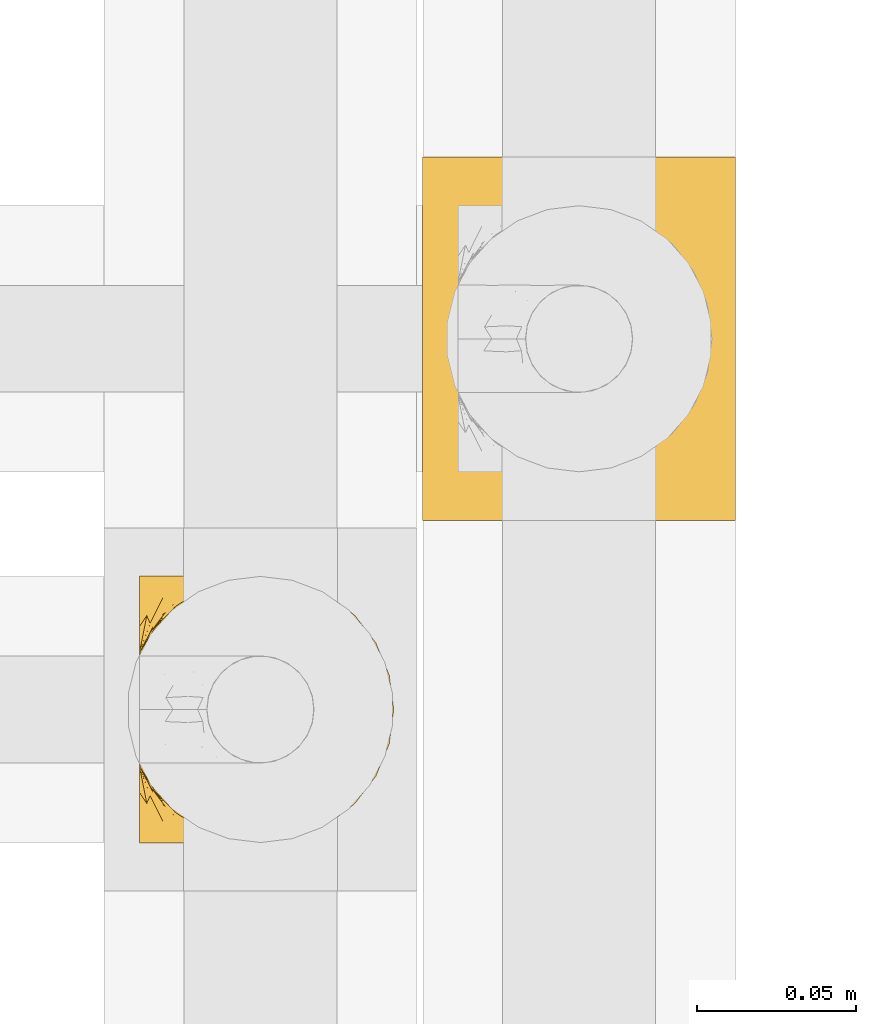
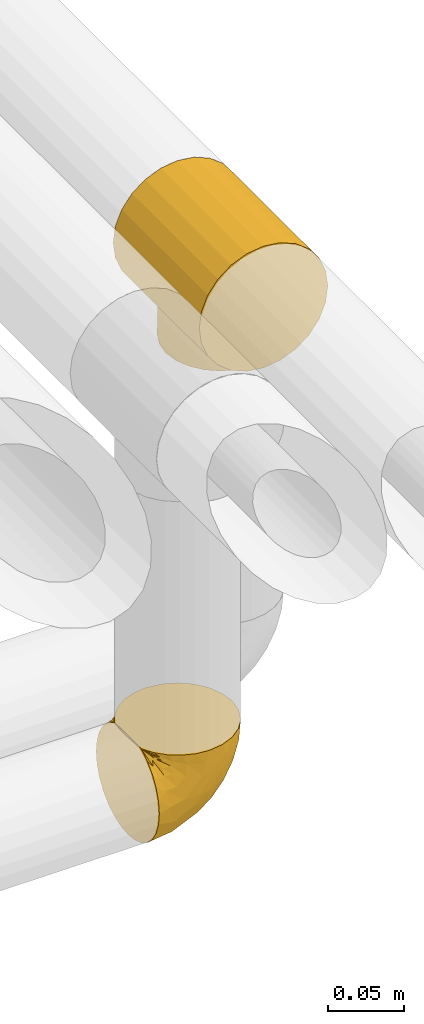
# One storey, part 492 of 827: 2 coverings.
"""IFC2X3 building model written with IfcOpenShell, lengths in millimetres."""

import ifcopenshell
import ifcopenshell.guid

model = None  # the IFC model being written
_history = None  # IfcOwnerHistory: only IFC2X3 demands one
_inside = {}  # id of a spatial element -> (the spatial element, [elements in it])
_under = {}  # id of a project, library or spatial element -> (it, [spatial elements below it])
_declared = {}  # id of a project -> (the project, [libraries it declares])
_typed = {}  # id of a type object -> (the type object, [elements of that type])
_made_of = {}  # id of a material, layer set ... -> (it, [elements and type objects made of it])


def new_model(schema):
    """Start an empty IFC model of exactly this schema.

    Asked for "IFC4X3", IfcOpenShell would pick the latest addendum, in which some entities
    have other attributes; the version numbers below select the first issue.
    IFC2X3 requires an IfcOwnerHistory on every rooted entity: one is made here for all.
    """
    global model, _history
    if schema == "IFC4X3":
        model = ifcopenshell.file(schema_version=(4, 3, 0, 0))
    else:
        model = ifcopenshell.file(schema=schema)
    _inside.clear()
    _under.clear()
    _declared.clear()
    _typed.clear()
    _made_of.clear()
    _history = None
    if model.schema == "IFC2X3":
        org = make("IfcOrganization", Name="unknown")
        user = make(
            "IfcPersonAndOrganization",
            ThePerson=make("IfcPerson", FamilyName="unknown"),
            TheOrganization=org,
        )
        app = make(
            "IfcApplication",
            ApplicationDeveloper=org,
            Version="unknown",
            ApplicationFullName="unknown",
            ApplicationIdentifier="unknown",
        )
        _history = make(
            "IfcOwnerHistory",
            OwningUser=user,
            OwningApplication=app,
            ChangeAction="ADDED",
            CreationDate=0,
        )
    return model


def make(cls, **values):
    """One entity of the class cls with the attributes given. An attribute that is None is left unset."""
    return model.create_entity(
        cls, **{name: value for name, value in values.items() if value is not None}
    )


def entity(cls, *values):
    """Any entity or typed value of the class cls, its attributes in the order of the schema. None: left unset."""
    e = model.create_entity(cls)
    for i, value in enumerate(values):
        if value is not None:
            e[i] = value
    return e


def rooted(cls, **values):
    """An entity with a GlobalId (a new one), such as an element, a storey or a relation."""
    return make(cls, GlobalId=ifcopenshell.guid.new(), OwnerHistory=_history, **values)


def si_unit(unit_type, name, prefix=None):
    """IfcSIUnit, for example si_unit("LENGTHUNIT", "METRE", prefix="MILLI")."""
    return make("IfcSIUnit", UnitType=unit_type, Prefix=prefix, Name=name)


def converted_unit(unit_type, name, factor, base, dimensions=None, offset=None):
    """IfcConversionBasedUnit, such as the inch: factor (a typed value) times the base unit."""
    return make(
        "IfcConversionBasedUnit"
        if offset is None
        else "IfcConversionBasedUnitWithOffset",
        ConversionOffset=offset,
        Dimensions=None
        if dimensions is None
        else entity("IfcDimensionalExponents", *dimensions),
        UnitType=unit_type,
        Name=name,
        ConversionFactor=make(
            "IfcMeasureWithUnit", ValueComponent=factor, UnitComponent=base
        ),
    )


def derived_unit(unit_type, elements):
    """IfcDerivedUnit: a product of units, each with its exponent."""
    return make(
        "IfcDerivedUnit",
        Elements=[
            make("IfcDerivedUnitElement", Unit=unit, Exponent=power)
            for unit, power in elements
        ],
        UnitType=unit_type,
    )


def assignment(units):
    """IfcUnitAssignment: the units of a project."""
    return None if units is None else make("IfcUnitAssignment", Units=units)


def point(xyz):
    """IfcCartesianPoint."""
    return None if xyz is None else make("IfcCartesianPoint", Coordinates=xyz)


def direction(xyz):
    """IfcDirection."""
    return None if xyz is None else make("IfcDirection", DirectionRatios=xyz)


def frame(location, z_axis=None, x_axis=None):
    """IfcAxis2Placement3D, a coordinate frame: its origin and axes. An axis left out is left unset."""
    return make(
        "IfcAxis2Placement3D",
        Location=point(location),
        Axis=direction(z_axis),
        RefDirection=direction(x_axis),
    )


def origin():
    """The frame at (0, 0, 0) with its axes left unset."""
    return frame((0.0, 0.0, 0.0))


def place(relative_to, where):
    """IfcLocalPlacement: puts the frame where relative to a parent placement (None: the world)."""
    return make(
        "IfcLocalPlacement", PlacementRelTo=relative_to, RelativePlacement=where
    )


def context(
    kind, dimensions, precision=None, world=None, true_north=None, identifier=None
):
    """IfcGeometricRepresentationContext, for example the 3D "Model" context."""
    return make(
        "IfcGeometricRepresentationContext",
        ContextIdentifier=identifier,
        ContextType=kind,
        CoordinateSpaceDimension=dimensions,
        Precision=precision,
        WorldCoordinateSystem=world,
        TrueNorth=true_north,
    )


def subcontext(parent, identifier, kind, view, scale=None):
    """IfcGeometricRepresentationSubContext, for example "Body" below "Model"."""
    return make(
        "IfcGeometricRepresentationSubContext",
        ContextIdentifier=identifier,
        ContextType=kind,
        ParentContext=parent,
        TargetScale=scale,
        TargetView=view,
    )


def project(units=None, contexts=None):
    """IfcProject with its units and contexts."""
    return rooted(
        "IfcProject",
        Name="project",
        RepresentationContexts=contexts,
        UnitsInContext=assignment(units),
    )


def spatial(cls, under=None, at=None, **own):
    """A site, building, storey or space (cls), placed at a placement, below another one or the project."""
    s = rooted(cls, ObjectPlacement=at, **own)
    if under is not None:
        _under.setdefault(under.id(), (under, []))[1].append(s)
    return s


def faces_of(points, faces, orient=None, outer=None):
    """IfcFace entities. A face is a list of loops; a loop is a list of indices into points, from 0.

    orient and outer hold one flag for each loop. By default every Orientation is true, the
    first loop of a face is its IfcFaceOuterBound and the others are IfcFaceBound.
    """
    made = []
    for i, loops in enumerate(faces):
        bounds = []
        for j, loop in enumerate(loops):
            is_outer = j == 0 if outer is None else outer[i][j]
            bounds.append(
                make(
                    "IfcFaceOuterBound" if is_outer else "IfcFaceBound",
                    Bound=make("IfcPolyLoop", Polygon=[points[k] for k in loop]),
                    Orientation=True if orient is None else orient[i][j],
                )
            )
        made.append(make("IfcFace", Bounds=bounds))
    return made


def faceted_brep(points, faces, orient=None, outer=None, voids=None):
    """IfcFacetedBrep: a solid bounded by flat faces; with voids (closed shells), ...WithVoids."""
    shared = [point(p) for p in points]
    hull = make("IfcClosedShell", CfsFaces=faces_of(shared, faces, orient, outer))
    if voids is None:
        return make("IfcFacetedBrep", Outer=hull)
    return make(
        "IfcFacetedBrepWithVoids",
        Outer=hull,
        Voids=[
            make(cls, CfsFaces=faces_of(shared, fs, o, b)) for cls, fs, o, b in voids
        ],
    )


def shape(context_of_items, identifier, shape_type, items):
    """IfcShapeRepresentation: the items that make up one representation, for example the "Body"."""
    return make(
        "IfcShapeRepresentation",
        ContextOfItems=context_of_items,
        RepresentationIdentifier=identifier,
        RepresentationType=shape_type,
        Items=items,
    )


def made_of(thing, what):
    """Note that an element or type object is made of a material, layer set ...; save() writes the relation."""
    if what is not None:
        _made_of.setdefault(what.id(), (what, []))[1].append(thing)
    return thing


def element(
    cls,
    number,
    at=None,
    inside=None,
    cuts=None,
    type_object=None,
    material=None,
    context=None,
    identifier="Body",
    shape_type=None,
    held_by="IfcProductDefinitionShape",
    body=None,
    shapes=None,
    **own,
):
    """One element of the class cls, such as IfcWall. Its Tag is "e" and its number.

    at: its placement. inside: the storey or other place that contains it. cuts: it is an
    opening in that element (IfcRelVoidsElement). A single representation is given by context,
    identifier, shape_type and body (its items); several are given by shapes. held_by: the class
    of the entity that holds the representations. save() writes the other relations.
    """
    e = rooted(cls, Tag="e%d" % number, ObjectPlacement=at, **own)
    if body is not None:
        shapes = [shape(context, identifier, shape_type, body)]
    if shapes is not None:
        e.Representation = make(held_by, Representations=shapes)
    if inside is not None:
        _inside.setdefault(inside.id(), (inside, []))[1].append(e)
    if cuts is not None:
        rooted(
            "IfcRelVoidsElement", RelatingBuildingElement=cuts, RelatedOpeningElement=e
        )
    if type_object is not None:
        _typed.setdefault(type_object.id(), (type_object, []))[1].append(e)
    return made_of(e, material)


def aggregate(whole, parts):
    """IfcRelAggregates: a whole, such as a stair, and the parts it consists of."""
    return rooted("IfcRelAggregates", RelatingObject=whole, RelatedObjects=parts)


def save(model, path):
    """Write the relations noted so far, then the file.

    IfcRelAggregates (storeys below a building ...), IfcRelContainedInSpatialStructure (elements
    in a storey), IfcRelDefinesByType, IfcRelAssociatesMaterial and IfcRelDeclares: one each for
    every whole, place, type object, material and project.
    """
    for whole, parts in _under.values():
        aggregate(whole, parts)
    for where, things in _inside.values():
        rooted(
            "IfcRelContainedInSpatialStructure",
            RelatedElements=things,
            RelatingStructure=where,
        )
    for kind, things in _typed.values():
        rooted("IfcRelDefinesByType", RelatedObjects=things, RelatingType=kind)
    for what, things in _made_of.values():
        rooted("IfcRelAssociatesMaterial", RelatedObjects=things, RelatingMaterial=what)
    for by, libraries in _declared.values():
        rooted("IfcRelDeclares", RelatingContext=by, RelatedDefinitions=libraries)
    model.write(path)


model = new_model("IFC2X3")

# Units and contexts
model_context = context("Model", 3, precision=0.01, world=origin(), true_north=direction((6.12303176911189e-17, 1.0)))
body_context = subcontext(model_context, "Body", "Model", "MODEL_VIEW")
ifc_project = project(units=[si_unit("LENGTHUNIT", "METRE", prefix="MILLI"), si_unit("AREAUNIT", "SQUARE_METRE"), si_unit("VOLUMEUNIT", "CUBIC_METRE"), converted_unit("PLANEANGLEUNIT", "DEGREE", entity("IfcRatioMeasure", 0.0174532925199433), si_unit("PLANEANGLEUNIT", "RADIAN"), dimensions=[0, 0, 0, 0, 0, 0, 0]), si_unit("MASSUNIT", "GRAM", prefix="KILO"), derived_unit("MASSDENSITYUNIT", [(si_unit("MASSUNIT", "GRAM", prefix="KILO"), 1), (si_unit("LENGTHUNIT", "METRE"), -3)]), derived_unit("MOMENTOFINERTIAUNIT", [(si_unit("LENGTHUNIT", "METRE"), 4)]), si_unit("TIMEUNIT", "SECOND"), si_unit("FREQUENCYUNIT", "HERTZ"), si_unit("THERMODYNAMICTEMPERATUREUNIT", "DEGREE_CELSIUS"), derived_unit("THERMALTRANSMITTANCEUNIT", [(si_unit("MASSUNIT", "GRAM", prefix="KILO"), 1), (si_unit("THERMODYNAMICTEMPERATUREUNIT", "KELVIN"), -1), (si_unit("TIMEUNIT", "SECOND"), -3)]), derived_unit("VOLUMETRICFLOWRATEUNIT", [(si_unit("LENGTHUNIT", "METRE"), 3), (si_unit("TIMEUNIT", "SECOND"), -1)]), derived_unit("MASSFLOWRATEUNIT", [(si_unit("MASSUNIT", "GRAM", prefix="KILO"), 1), (si_unit("TIMEUNIT", "SECOND"), -1)]), derived_unit("ROTATIONALFREQUENCYUNIT", [(si_unit("TIMEUNIT", "SECOND"), -1)]), si_unit("ELECTRICCURRENTUNIT", "AMPERE"), si_unit("ELECTRICVOLTAGEUNIT", "VOLT"), si_unit("POWERUNIT", "WATT"), si_unit("FORCEUNIT", "NEWTON", prefix="KILO"), si_unit("ILLUMINANCEUNIT", "LUX"), si_unit("LUMINOUSFLUXUNIT", "LUMEN"), si_unit("LUMINOUSINTENSITYUNIT", "CANDELA"), derived_unit("USERDEFINED", [(si_unit("MASSUNIT", "GRAM", prefix="KILO"), -1), (si_unit("LENGTHUNIT", "METRE"), -2), (si_unit("TIMEUNIT", "SECOND"), 3), (si_unit("LUMINOUSFLUXUNIT", "LUMEN"), 1)]), derived_unit("LINEARVELOCITYUNIT", [(si_unit("LENGTHUNIT", "METRE"), 1), (si_unit("TIMEUNIT", "SECOND"), -1)]), si_unit("PRESSUREUNIT", "PASCAL"), derived_unit("USERDEFINED", [(si_unit("LENGTHUNIT", "METRE"), -2), (si_unit("MASSUNIT", "GRAM", prefix="KILO"), 1), (si_unit("TIMEUNIT", "SECOND"), -2)]), derived_unit("LINEARFORCEUNIT", [(si_unit("MASSUNIT", "GRAM", prefix="KILO"), 1), (si_unit("LENGTHUNIT", "METRE"), 1), (si_unit("TIMEUNIT", "SECOND"), -2), (si_unit("LENGTHUNIT", "METRE"), -1)]), derived_unit("PLANARFORCEUNIT", [(si_unit("MASSUNIT", "GRAM", prefix="KILO"), 1), (si_unit("LENGTHUNIT", "METRE"), 1), (si_unit("TIMEUNIT", "SECOND"), -2), (si_unit("LENGTHUNIT", "METRE"), -2)])], contexts=[model_context])

# Site, building, storey
site_placement = place(None, origin())
site = spatial("IfcSite", under=ifc_project, at=site_placement, CompositionType="ELEMENT")
building_placement = place(site_placement, origin())
building = spatial("IfcBuilding", under=site, at=building_placement, CompositionType="ELEMENT")
storey_placement = place(building_placement, frame((0.0, 0.0, 28200.0)))
storey = spatial("IfcBuildingStorey", under=building, at=storey_placement, Name="08", CompositionType="ELEMENT", Elevation=28200.0)

# Coverings
covering_1_placement = place(storey_placement, frame((61013.04, 15400.76, 2656.55)))
element("IfcCovering", 1, at=covering_1_placement, inside=storey, Name=":ADSK_", ObjectType=":ADSK_", PredefinedType="INSULATION", context=body_context, shape_type="Brep", body=[
    faceted_brep([(1.6, 81.15, 25.28), (1.6, 76.16, 17.35), (1.6, 69.53, 10.72), (1.6, 61.6, 5.74), (1.6, 52.75, 2.64), (1.6, 43.45, 1.6), (1.6, 34.13, 2.65), (1.6, 25.28, 5.74), (1.6, 17.35, 10.73), (1.6, 10.72, 17.36), (1.6, 5.74, 25.29), (1.6, 2.64, 34.14), (1.6, 1.6, 43.45), (1.6, 2.66, 52.82), (1.6, 5.79, 61.71), (1.6, 10.83, 69.67), (1.6, 17.53, 76.31), (1.6, 25.53, 81.27), (1.6, 26.45, 81.27), (1.6, 27.37, 81.27), (1.6, 28.17, 81.27), (1.6, 29.49, 81.27), (1.6, 30.81, 81.27), (1.6, 32.13, 81.27), (1.6, 33.45, 81.27), (1.6, 34.78, 81.27), (1.6, 36.1, 81.27), (1.6, 37.42, 81.27), (1.6, 38.74, 81.27), (1.6, 40.06, 81.27), (1.6, 41.38, 81.27), (1.6, 42.7, 81.27), (1.6, 44.02, 81.27), (1.6, 45.34, 81.27), (1.6, 46.66, 81.27), (1.6, 47.58, 81.27), (1.6, 48.5, 81.27), (1.6, 49.41, 81.27), (1.6, 50.33, 81.27), (1.6, 51.25, 81.27), (1.6, 52.17, 81.27), (1.6, 53.09, 81.27), (1.6, 54.01, 81.27), (1.6, 54.93, 81.27), (1.6, 55.85, 81.27), (1.6, 56.76, 81.27), (1.6, 57.68, 81.27), (1.6, 58.6, 81.27), (1.6, 59.52, 81.27), (1.6, 60.44, 81.27), (1.6, 61.36, 81.27), (1.6, 69.37, 76.3), (1.6, 76.07, 69.66), (1.6, 81.11, 61.69), (1.6, 84.24, 52.8), (1.6, 85.3, 43.45), (1.6, 84.24, 34.13), (6.74, 17.52, 81.45), (13.37, 10.83, 81.45), (21.34, 5.79, 81.45), (30.23, 2.66, 81.45), (39.6, 1.6, 81.45), (50.43, 3.02, 81.45), (60.52, 7.2, 81.45), (69.19, 13.85, 81.45), (75.84, 22.52, 81.45), (80.02, 32.61, 81.45), (81.45, 43.45, 81.45), (80.02, 54.28, 81.45), (75.84, 64.37, 81.45), (69.19, 73.04, 81.45), (60.52, 79.69, 81.45), (50.43, 83.87, 81.45), (39.6, 85.3, 81.45), (30.23, 84.23, 81.45), (21.34, 81.1, 81.45), (13.37, 76.06, 81.45), (6.74, 69.37, 81.45), (1.77, 61.36, 81.45), (1.77, 60.44, 81.45), (1.77, 59.12, 81.45), (1.77, 58.0, 81.45), (1.77, 56.88, 81.45), (1.77, 55.76, 81.45), (1.77, 54.64, 81.45), (1.77, 53.52, 81.45), (1.77, 52.4, 81.45), (1.77, 51.28, 81.45), (1.77, 50.16, 81.45), (1.77, 49.04, 81.45), (1.77, 47.92, 81.45), (1.77, 46.8, 81.45), (1.77, 45.68, 81.45), (1.77, 44.56, 81.45), (1.77, 43.45, 81.45), (1.77, 42.12, 81.45), (1.77, 40.8, 81.45), (1.77, 39.48, 81.45), (1.77, 38.16, 81.45), (1.77, 36.84, 81.45), (1.77, 35.52, 81.45), (1.77, 34.2, 81.45), (1.77, 32.88, 81.45), (1.77, 31.96, 81.45), (1.77, 31.05, 81.45), (1.77, 30.13, 81.45), (1.77, 29.21, 81.45), (1.77, 28.29, 81.45), (1.77, 27.37, 81.45), (1.77, 26.45, 81.45), (1.77, 25.53, 81.45), (1.73, 54.08, 81.33), (1.72, 55.16, 81.32), (1.73, 36.18, 81.33), (1.72, 35.13, 81.32), (1.73, 44.01, 81.33), (1.73, 45.08, 81.32), (1.72, 61.36, 81.32), (1.72, 59.98, 81.32), (1.72, 46.18, 81.32), (1.72, 26.74, 81.32), (1.72, 47.36, 81.32), (1.73, 29.67, 81.32), (1.74, 28.72, 81.34), (1.72, 39.77, 81.32), (1.71, 52.96, 81.31), (1.73, 51.84, 81.33), (1.71, 40.8, 81.31), (1.72, 41.87, 81.32), (1.73, 42.94, 81.33), (1.72, 27.77, 81.32), (1.73, 48.4, 81.33), (1.72, 37.21, 81.32), (1.73, 33.54, 81.33), (1.72, 32.49, 81.32), (1.72, 30.69, 81.32), (1.72, 50.69, 81.32), (1.71, 49.6, 81.31), (1.72, 56.32, 81.32), (1.73, 57.44, 81.33), (1.71, 58.88, 81.31), (1.72, 25.53, 81.32), (1.68, 61.36, 81.3), (1.64, 61.36, 81.29), (1.64, 25.53, 81.29), (1.68, 25.53, 81.3), (1.75, 61.36, 81.4), (1.74, 61.36, 81.36), (1.74, 25.53, 81.36), (1.75, 25.53, 81.4), (1.7, 31.59, 81.3), (1.73, 38.71, 81.33), (24.54, 3.97, 74.06), (11.1, 1.6, 45.99), (8.47, 3.97, 58.35), (9.11, 8.09, 67.76), (4.86, 8.09, 66.18), (5.0, 16.43, 76.46), (6.81, 15.73, 77.33), (37.05, 1.6, 71.95), (9.03, 10.79, 72.25), (9.47, 13.99, 78.91), (16.39, 8.08, 76.42), (3.95, 14.0, 73.52), (9.9, 12.83, 76.9), (22.7, 3.18, 65.25), (34.5, 1.6, 62.45), (37.68, 1.6, 74.31), (15.82, 3.28, 59.38), (20.6, 1.6, 48.54), (14.37, 6.28, 67.72), (27.55, 1.6, 55.49), (5.2, 19.06, 79.73), (14.88, 8.08, 73.23), (8.73, 1.6, 45.36), (44.27, 32.11, 15.81), (20.94, 29.62, 6.4), (32.15, 43.45, 7.67), (46.13, 2.45, 68.46), (42.67, 2.5, 59.33), (55.18, 9.73, 48.7), (67.27, 17.97, 53.94), (62.91, 10.24, 65.02), (51.5, 4.78, 60.77), (54.79, 4.78, 72.07), (25.78, 8.01, 26.25), (13.05, 8.01, 22.29), (18.46, 13.85, 16.0), (32.4, 2.42, 46.93), (31.07, 21.17, 14.19), (77.32, 35.73, 58.46), (75.62, 27.43, 61.51), (16.9, 43.45, 4.64), (71.69, 17.97, 68.93), (61.4, 35.71, 29.62), (54.47, 29.47, 24.85), (27.66, 3.41, 38.55), (14.53, 3.94, 31.27), (15.56, 21.17, 9.35), (42.26, 7.92, 37.15), (41.51, 4.25, 47.07), (36.93, 11.75, 26.49), (42.72, 18.31, 23.01), (44.68, 24.94, 19.4), (71.2, 28.78, 48.06), (70.48, 35.82, 42.46), (75.37, 43.45, 50.89), (63.65, 28.38, 35.78), (58.06, 43.45, 24.98), (45.11, 43.45, 16.33), (78.4, 43.45, 66.14), (54.95, 21.21, 30.96), (59.31, 16.48, 41.83), (49.01, 13.85, 33.28), (66.71, 43.45, 37.94), (53.75, 82.11, 67.39), (77.27, 51.41, 58.47), (61.6, 57.45, 32.5), (44.24, 54.78, 15.79), (18.46, 73.03, 15.99), (15.55, 65.7, 9.34), (60.14, 76.65, 56.91), (70.5, 68.92, 63.5), (63.0, 68.01, 44.08), (25.78, 78.88, 26.24), (13.05, 78.88, 22.27), (14.53, 82.94, 31.26), (48.5, 64.44, 23.95), (44.23, 84.49, 63.79), (34.5, 85.3, 62.45), (37.05, 85.3, 71.95), (8.73, 85.3, 45.36), (77.68, 57.84, 67.83), (64.08, 76.65, 70.28), (70.25, 51.19, 42.11), (20.93, 57.26, 6.39), (49.9, 78.14, 43.54), (49.6, 82.35, 58.03), (31.06, 65.7, 14.18), (39.62, 84.61, 56.34), (34.42, 84.36, 48.09), (20.6, 85.3, 48.54), (27.55, 85.3, 55.49), (33.36, 73.03, 21.78), (27.68, 83.48, 38.54), (11.1, 85.3, 45.99), (46.67, 84.54, 72.79), (49.0, 73.03, 33.26), (38.94, 79.54, 35.53), (73.05, 59.46, 53.66), (56.63, 73.5, 43.03), (43.85, 82.57, 49.68), (24.54, 82.92, 74.06), (15.82, 83.62, 59.37), (8.47, 82.92, 58.34), (9.12, 78.81, 67.75), (9.47, 72.9, 78.91), (9.91, 74.06, 76.9), (16.85, 78.81, 78.08), (14.88, 78.81, 73.23), (5.2, 67.83, 79.73), (6.81, 71.15, 77.34), (3.96, 72.91, 73.51), (5.0, 70.47, 76.45), (5.86, 78.81, 66.41), (14.38, 80.62, 67.7), (9.04, 76.11, 72.24), (22.7, 83.71, 65.25)], [[[0, 1, 2, 3, 4, 5, 6, 7, 8, 9, 10, 11, 12, 13, 14, 15, 16, 17, 18, 19, 20, 21, 22, 23, 24, 25, 26, 27, 28, 29, 30, 31, 32, 33, 34, 35, 36, 37, 38, 39, 40, 41, 42, 43, 44, 45, 46, 47, 48, 49, 50, 51, 52, 53, 54, 55, 56]], [[57, 58, 59, 60, 61, 62, 63, 64, 65, 66, 67, 68, 69, 70, 71, 72, 73, 74, 75, 76, 77, 78, 79, 80, 81, 82, 83, 84, 85, 86, 87, 88, 89, 90, 91, 92, 93, 94, 95, 96, 97, 98, 99, 100, 101, 102, 103, 104, 105, 106, 107, 108, 109, 110]], [[111, 84, 112]], [[113, 26, 114]], [[114, 101, 100]], [[115, 93, 116]], [[79, 117, 118]], [[33, 116, 119]], [[117, 49, 118]], [[19, 18, 120]], [[119, 121, 34]], [[122, 21, 123]], [[97, 96, 124]], [[86, 125, 126]], [[116, 92, 119]], [[127, 96, 128]], [[32, 129, 115]], [[19, 120, 130]], [[121, 90, 131]], [[94, 115, 129]], [[115, 116, 32]], [[118, 49, 48]], [[113, 99, 132]], [[133, 114, 25]], [[24, 134, 133]], [[135, 22, 122]], [[136, 137, 88]], [[84, 83, 112]], [[138, 82, 139]], [[130, 20, 19]], [[118, 48, 140]], [[81, 140, 139]], [[123, 21, 20]], [[141, 120, 18]], [[139, 82, 81]], [[130, 107, 123]], [[49, 117, 142, 143]], [[18, 17, 144]], [[18, 145, 141]], [[79, 78, 146, 147, 117]], [[109, 141, 148, 149, 110]], [[102, 133, 134]], [[105, 135, 122]], [[118, 80, 79]], [[80, 118, 140]], [[120, 109, 108]], [[47, 46, 140, 48]], [[81, 80, 140]], [[44, 112, 138]], [[93, 115, 94]], [[46, 139, 140]], [[46, 45, 139]], [[139, 45, 138]], [[138, 112, 83]], [[85, 84, 111]], [[112, 43, 111]], [[83, 82, 138]], [[106, 122, 123]], [[105, 122, 106]], [[21, 122, 22]], [[124, 29, 28]], [[33, 32, 116]], [[128, 129, 31]], [[32, 31, 129]], [[34, 33, 119]], [[116, 93, 92]], [[129, 95, 94]], [[95, 129, 128]], [[41, 40, 125, 42]], [[119, 91, 121]], [[36, 35, 131, 37]], [[137, 131, 89]], [[121, 131, 35]], [[90, 121, 91]], [[119, 92, 91]], [[136, 126, 39]], [[125, 86, 85]], [[42, 125, 111]], [[85, 111, 125]], [[150, 23, 22]], [[130, 108, 107]], [[130, 123, 20]], [[107, 106, 123]], [[137, 37, 131]], [[136, 38, 137]], [[89, 88, 137]], [[131, 90, 89]], [[124, 151, 97]], [[40, 39, 126]], [[87, 126, 136]], [[86, 126, 87]], [[136, 88, 87]], [[40, 126, 125]], [[39, 38, 136]], [[95, 128, 96]], [[30, 128, 31]], [[29, 124, 127]], [[127, 128, 30]], [[151, 124, 28]], [[127, 30, 29]], [[127, 124, 96]], [[151, 98, 97]], [[45, 44, 138]], [[26, 113, 132]], [[113, 100, 99]], [[132, 151, 27]], [[27, 26, 132]], [[26, 25, 114]], [[100, 113, 114]], [[101, 133, 102]], [[133, 101, 114]], [[28, 27, 151]], [[132, 99, 98]], [[23, 134, 24]], [[25, 24, 133]], [[134, 23, 150]], [[135, 104, 150]], [[150, 104, 103]], [[103, 102, 134]], [[130, 120, 108]], [[109, 120, 141]], [[42, 111, 43]], [[112, 44, 43]], [[104, 135, 105]], [[134, 150, 103]], [[135, 150, 22]], [[35, 34, 121]], [[137, 38, 37]], [[98, 151, 132]], [[59, 152, 60]], [[13, 153, 154]], [[155, 156, 154]], [[157, 158, 141]], [[159, 60, 152]], [[160, 157, 155]], [[161, 162, 58]], [[58, 162, 59]], [[144, 16, 163]], [[58, 57, 161]], [[162, 161, 164]], [[157, 163, 155]], [[163, 16, 15]], [[57, 149, 161]], [[152, 165, 166]], [[157, 144, 163]], [[60, 159, 167, 61]], [[156, 14, 154]], [[163, 156, 155]], [[155, 154, 168]], [[168, 154, 169]], [[155, 170, 160]], [[57, 110, 149]], [[144, 17, 16]], [[156, 15, 14]], [[171, 165, 168]], [[158, 164, 172]], [[14, 13, 154]], [[157, 145, 144]], [[173, 164, 158]], [[173, 160, 170]], [[171, 166, 165]], [[168, 165, 170]], [[168, 169, 171]], [[152, 173, 165]], [[170, 155, 168]], [[165, 173, 170]], [[160, 173, 158]], [[172, 149, 148]], [[148, 141, 158]], [[158, 157, 160]], [[152, 166, 159]], [[173, 152, 162]], [[59, 162, 152]], [[13, 12, 174, 153]], [[153, 169, 154]], [[15, 156, 163]], [[157, 141, 145]], [[162, 164, 173]], [[172, 164, 161]], [[149, 172, 161]], [[158, 172, 148]], [[175, 176, 177]], [[178, 166, 179]], [[180, 181, 182]], [[183, 184, 178]], [[185, 186, 187]], [[171, 188, 179]], [[174, 12, 11]], [[189, 176, 175]], [[190, 66, 191]], [[176, 6, 192]], [[193, 65, 64]], [[63, 184, 182]], [[63, 182, 64]], [[65, 193, 191]], [[184, 63, 62]], [[175, 194, 195]], [[196, 169, 197]], [[174, 11, 197]], [[8, 7, 198]], [[187, 9, 8]], [[197, 169, 153, 174]], [[197, 11, 10]], [[186, 197, 10]], [[199, 180, 200]], [[197, 185, 196]], [[201, 189, 202]], [[201, 187, 189]], [[195, 203, 175]], [[191, 204, 190]], [[176, 7, 6]], [[177, 176, 192]], [[189, 198, 176]], [[65, 191, 66]], [[198, 187, 8]], [[205, 206, 190]], [[9, 186, 10]], [[181, 207, 204]], [[208, 175, 177, 209]], [[66, 190, 210]], [[211, 212, 213]], [[190, 204, 205]], [[180, 182, 183]], [[193, 182, 181]], [[62, 61, 167]], [[196, 185, 199]], [[196, 200, 188]], [[6, 5, 192]], [[176, 198, 7]], [[187, 198, 189]], [[187, 186, 9]], [[197, 186, 185]], [[200, 180, 183]], [[180, 213, 212]], [[179, 183, 178]], [[185, 201, 199]], [[210, 190, 206]], [[210, 67, 66]], [[205, 204, 207]], [[194, 205, 207]], [[194, 214, 205]], [[195, 194, 207]], [[208, 194, 175]], [[207, 211, 195]], [[202, 203, 211]], [[212, 207, 181]], [[202, 211, 213]], [[201, 202, 213]], [[189, 175, 203]], [[199, 201, 213]], [[187, 201, 185]], [[180, 199, 213]], [[196, 199, 200]], [[211, 203, 195]], [[189, 203, 202]], [[207, 212, 211]], [[180, 212, 181]], [[214, 194, 208]], [[214, 206, 205]], [[196, 188, 169]], [[181, 204, 191]], [[182, 193, 64]], [[191, 193, 181]], [[178, 62, 167]], [[182, 184, 183]], [[62, 178, 184]], [[178, 167, 159, 166]], [[171, 179, 166]], [[200, 183, 179]], [[179, 188, 200]], [[169, 188, 171]], [[71, 215, 72]], [[206, 216, 210]], [[217, 208, 218]], [[216, 68, 210]], [[219, 220, 2]], [[221, 222, 223]], [[224, 225, 226]], [[227, 223, 217]], [[228, 229, 230]], [[56, 231, 226]], [[232, 222, 69]], [[56, 55, 231]], [[70, 233, 71]], [[71, 233, 215]], [[0, 56, 226]], [[208, 217, 234]], [[218, 177, 235]], [[221, 236, 237]], [[238, 220, 219]], [[1, 219, 2]], [[68, 216, 232]], [[235, 3, 220]], [[235, 192, 4]], [[1, 0, 225]], [[228, 239, 229]], [[240, 241, 242]], [[243, 238, 219]], [[224, 226, 244]], [[226, 241, 244]], [[3, 235, 4]], [[69, 222, 70]], [[225, 219, 1]], [[218, 235, 238]], [[243, 219, 224]], [[218, 227, 217]], [[3, 2, 220]], [[218, 208, 209, 177]], [[226, 231, 245, 241]], [[215, 228, 246]], [[247, 248, 236]], [[248, 224, 244]], [[223, 222, 249]], [[233, 222, 221]], [[242, 239, 240]], [[248, 247, 243]], [[217, 223, 249]], [[250, 247, 236]], [[216, 234, 249]], [[218, 238, 227]], [[192, 235, 177]], [[192, 5, 4]], [[72, 246, 73]], [[235, 220, 238]], [[226, 225, 0]], [[219, 225, 224]], [[240, 248, 244]], [[239, 242, 229]], [[236, 248, 251]], [[68, 67, 210]], [[234, 216, 206]], [[216, 249, 232]], [[234, 206, 214, 208]], [[249, 234, 217]], [[222, 232, 249]], [[69, 68, 232]], [[246, 228, 230]], [[237, 228, 215]], [[243, 227, 238]], [[223, 227, 247]], [[73, 246, 230]], [[215, 246, 72]], [[248, 243, 224]], [[227, 243, 247]], [[237, 236, 251]], [[250, 221, 223]], [[222, 233, 70]], [[215, 233, 221]], [[221, 237, 215]], [[239, 237, 251]], [[237, 239, 228]], [[239, 251, 240]], [[248, 240, 251]], [[241, 240, 244]], [[221, 250, 236]], [[223, 247, 250]], [[74, 230, 252]], [[253, 254, 255]], [[146, 77, 256]], [[257, 258, 259]], [[260, 256, 257]], [[260, 261, 147]], [[75, 74, 252]], [[51, 143, 262]], [[263, 143, 142, 117]], [[256, 77, 76]], [[252, 258, 75]], [[253, 241, 254]], [[254, 245, 54]], [[258, 256, 76]], [[53, 52, 264]], [[255, 265, 253]], [[254, 264, 255]], [[255, 264, 262]], [[75, 258, 76]], [[265, 255, 266]], [[255, 262, 263]], [[51, 50, 143]], [[54, 245, 231, 55]], [[51, 262, 52]], [[253, 267, 242]], [[254, 54, 53]], [[266, 259, 265]], [[146, 78, 77]], [[263, 117, 261]], [[146, 256, 260]], [[257, 259, 261]], [[267, 253, 265]], [[229, 267, 252]], [[242, 267, 229]], [[242, 241, 253]], [[252, 267, 259]], [[255, 263, 266]], [[259, 267, 265]], [[261, 117, 147]], [[263, 261, 266]], [[259, 266, 261]], [[230, 74, 73]], [[230, 229, 252]], [[259, 258, 252]], [[254, 241, 245]], [[53, 264, 254]], [[52, 262, 264]], [[143, 263, 262]], [[258, 257, 256]], [[261, 260, 257]], [[146, 260, 147]], [[49, 143, 50]], [[18, 144, 145]]]),
])
covering_2_placement = place(storey_placement, frame((61101.89, 15503.52, 2942.74)))
element("IfcCovering", 2, at=covering_2_placement, inside=storey, Name=":ADSK_", ObjectType=":ADSK_", PredefinedType="INSULATION", context=body_context, shape_type="Brep", body=[
    faceted_brep([(26.17, 114.0, 99.57), (38.02, 114.0, 104.48), (50.75, 114.0, 106.15), (63.47, 114.0, 104.48), (75.32, 114.0, 99.57), (85.5, 114.0, 91.75), (93.31, 114.0, 81.58), (98.22, 114.0, 69.72), (99.9, 114.0, 57.0), (98.22, 114.0, 44.28), (93.31, 114.0, 32.43), (89.4, 114.0, 27.34), (85.5, 114.0, 22.25), (80.41, 114.0, 18.34), (75.32, 114.0, 14.43), (69.39, 114.0, 11.98), (66.43, 114.0, 10.75), (63.47, 114.0, 9.52), (60.29, 114.0, 9.11), (57.11, 114.0, 8.69), (53.93, 114.0, 8.27), (50.75, 114.0, 7.85), (47.57, 114.0, 8.27), (44.38, 114.0, 8.69), (41.2, 114.0, 9.11), (38.02, 114.0, 9.52), (35.06, 114.0, 10.75), (32.1, 114.0, 11.98), (26.17, 114.0, 14.43), (21.08, 114.0, 18.34), (15.99, 114.0, 22.25), (12.09, 114.0, 27.34), (8.18, 114.0, 32.43), (3.27, 114.0, 44.28), (1.6, 114.0, 57.0), (3.27, 114.0, 69.72), (8.18, 114.0, 81.58), (15.99, 114.0, 91.75), (98.22, 0.0, 69.72), (93.31, 0.0, 81.58), (85.5, 0.0, 91.75), (75.32, 0.0, 99.57), (63.47, 0.0, 104.48), (50.75, 0.0, 106.15), (38.02, 0.0, 104.48), (26.17, 0.0, 99.57), (15.99, 0.0, 91.75), (8.18, 0.0, 81.58), (3.27, 0.0, 69.72), (1.6, 0.0, 57.0), (3.27, 0.0, 44.28), (8.18, 0.0, 32.43), (12.09, 0.0, 27.34), (15.99, 0.0, 22.25), (21.08, 0.0, 18.34), (26.17, 0.0, 14.43), (32.1, 0.0, 11.98), (35.06, 0.0, 10.75), (38.02, 0.0, 9.52), (41.2, 0.0, 9.11), (44.38, 0.0, 8.69), (47.57, 0.0, 8.27), (50.75, 0.0, 7.85), (53.93, 0.0, 8.27), (57.11, 0.0, 8.69), (60.29, 0.0, 9.11), (63.47, 0.0, 9.52), (66.43, 0.0, 10.75), (69.39, 0.0, 11.98), (75.32, 0.0, 14.43), (80.41, 0.0, 18.34), (85.5, 0.0, 22.25), (89.4, 0.0, 27.34), (93.31, 0.0, 32.43), (98.22, 0.0, 44.28), (99.9, 0.0, 57.0), (92.6, 57.0, 31.23), (83.63, 31.11, 20.47), (88.32, 38.57, 25.32), (69.73, 94.29, 11.67), (65.2, 95.97, 10.26), (91.44, 47.21, 29.43), (88.32, 75.43, 25.32), (53.23, 15.45, 8.1), (50.75, 15.15, 7.85), (53.23, 98.55, 8.1), (50.75, 98.85, 7.85), (60.68, 97.65, 8.86), (55.71, 98.25, 8.36), (91.44, 66.79, 29.43), (83.63, 82.89, 20.47), (77.43, 89.24, 15.72), (77.43, 24.76, 15.72), (73.58, 22.23, 13.69), (65.2, 18.03, 10.26), (60.68, 16.35, 8.86), (55.71, 15.75, 8.36), (69.73, 19.71, 11.67), (73.58, 91.77, 13.69), (45.78, 15.75, 8.36), (40.81, 16.35, 8.86), (40.81, 97.65, 8.86), (27.91, 22.23, 13.69), (24.06, 24.76, 15.72), (31.76, 19.71, 11.67), (17.86, 31.11, 20.47), (36.29, 18.03, 10.26), (48.26, 15.45, 8.1), (45.78, 98.25, 8.36), (13.17, 38.57, 25.32), (48.26, 98.55, 8.1), (27.91, 91.77, 13.69), (24.06, 89.24, 15.72), (36.29, 95.97, 10.26), (31.76, 94.29, 11.67), (10.06, 47.21, 29.43), (8.9, 57.0, 31.23), (13.17, 75.43, 25.32), (17.86, 82.89, 20.47), (10.06, 66.79, 29.43), (91.17, 46.17, 0.0), (86.99, 36.07, 0.0), (80.34, 27.41, 0.0), (71.67, 20.76, 0.0), (61.58, 16.58, 0.0), (50.75, 15.15, 0.0), (39.91, 16.58, 0.0), (29.82, 20.76, 0.0), (21.15, 27.41, 0.0), (14.5, 36.07, 0.0), (10.32, 46.17, 0.0), (8.9, 57.0, 0.0), (10.32, 67.83, 0.0), (14.5, 77.92, 0.0), (21.15, 86.59, 0.0), (29.82, 93.24, 0.0), (39.91, 97.42, 0.0), (50.75, 98.85, 0.0), (61.58, 97.42, 0.0), (71.67, 93.24, 0.0), (80.34, 86.59, 0.0), (86.99, 77.92, 0.0), (91.17, 67.83, 0.0), (92.6, 57.0, 0.0)], [[[0, 1, 2, 3, 4, 5, 6, 7, 8, 9, 10, 11, 12, 13, 14, 15, 16, 17, 18, 19, 20, 21, 22, 23, 24, 25, 26, 27, 28, 29, 30, 31, 32, 33, 34, 35, 36, 37]], [[38, 39, 40, 41, 42, 43, 44, 45, 46, 47, 48, 49, 50, 51, 52, 53, 54, 55, 56, 57, 58, 59, 60, 61, 62, 63, 64, 65, 66, 67, 68, 69, 70, 71, 72, 73, 74, 75]], [[41, 40, 5, 4]], [[2, 43, 42, 3]], [[42, 41, 4, 3]], [[6, 39, 38, 7]], [[7, 38, 75, 8]], [[5, 40, 39, 6]], [[74, 9, 8, 75]], [[73, 76, 74]], [[71, 77, 78]], [[71, 70, 77]], [[16, 79, 80]], [[73, 72, 81]], [[82, 12, 11]], [[78, 72, 71]], [[81, 76, 73]], [[9, 76, 10]], [[83, 62, 84]], [[21, 85, 86]], [[19, 87, 88]], [[11, 89, 82]], [[85, 21, 20]], [[10, 89, 11]], [[90, 12, 82]], [[91, 14, 13]], [[89, 10, 76]], [[74, 76, 9]], [[81, 72, 78]], [[80, 17, 16]], [[92, 69, 93]], [[77, 70, 92]], [[67, 66, 94]], [[95, 66, 65, 64]], [[96, 63, 83]], [[68, 93, 69]], [[95, 64, 96]], [[97, 68, 67]], [[79, 16, 15]], [[13, 12, 90]], [[93, 68, 97]], [[98, 15, 14]], [[15, 98, 79]], [[66, 95, 94]], [[13, 90, 91]], [[20, 19, 88]], [[14, 91, 98]], [[20, 88, 85]], [[18, 17, 87, 19]], [[97, 67, 94]], [[87, 17, 80]], [[62, 83, 63]], [[92, 70, 69]], [[96, 64, 63]], [[60, 99, 61]], [[100, 60, 59, 58]], [[101, 25, 24, 23]], [[55, 102, 56]], [[103, 55, 54]], [[104, 56, 102]], [[53, 105, 54]], [[58, 106, 100]], [[107, 62, 61]], [[101, 23, 108]], [[109, 53, 52]], [[22, 110, 108]], [[106, 58, 57]], [[111, 112, 28]], [[57, 104, 106]], [[110, 21, 86]], [[62, 107, 84]], [[25, 113, 26]], [[112, 29, 28]], [[26, 114, 27]], [[104, 57, 56]], [[60, 100, 99]], [[55, 103, 102]], [[105, 53, 109]], [[105, 103, 54]], [[52, 51, 115]], [[25, 101, 113]], [[116, 51, 50]], [[116, 115, 51]], [[115, 109, 52]], [[50, 49, 34, 33]], [[111, 27, 114]], [[30, 117, 31]], [[118, 29, 112]], [[30, 29, 118]], [[30, 118, 117]], [[119, 32, 31]], [[116, 32, 119]], [[32, 116, 33]], [[21, 110, 22]], [[33, 116, 50]], [[108, 23, 22]], [[119, 31, 117]], [[61, 99, 107]], [[27, 111, 28]], [[114, 26, 113]], [[35, 48, 47, 36]], [[36, 47, 46, 37]], [[49, 48, 35, 34]], [[0, 45, 44, 1]], [[1, 44, 43, 2]], [[37, 46, 45, 0]], [[120, 121, 122, 123, 124, 125, 126, 127, 128, 129, 130, 131, 132, 133, 134, 135, 136, 137, 138, 139, 140, 141, 142, 143]], [[95, 125, 124]], [[97, 124, 123]], [[125, 95, 96, 83, 84]], [[123, 92, 93, 97]], [[124, 97, 94, 95]], [[123, 122, 92]], [[122, 121, 77]], [[121, 120, 78]], [[81, 120, 143]], [[77, 121, 78]], [[81, 78, 120]], [[76, 81, 143]], [[122, 77, 92]], [[89, 143, 142]], [[82, 142, 141]], [[76, 143, 89]], [[89, 142, 82]], [[141, 90, 82]], [[141, 140, 90]], [[91, 140, 139]], [[138, 137, 87]], [[79, 139, 138]], [[139, 79, 98, 91]], [[137, 86, 85, 88, 87]], [[138, 87, 80, 79]], [[140, 91, 90]], [[101, 137, 136]], [[114, 136, 135]], [[137, 101, 108, 110, 86]], [[135, 112, 111, 114]], [[136, 114, 113, 101]], [[135, 134, 112]], [[118, 134, 133]], [[133, 132, 117]], [[131, 119, 132]], [[118, 133, 117]], [[119, 117, 132]], [[116, 119, 131]], [[134, 118, 112]], [[115, 131, 130]], [[109, 130, 129]], [[116, 131, 115]], [[115, 130, 109]], [[129, 105, 109]], [[129, 128, 105]], [[103, 128, 127]], [[127, 126, 104]], [[125, 100, 126]], [[127, 104, 102, 103]], [[125, 84, 107, 99, 100]], [[126, 100, 106, 104]], [[128, 103, 105]]]),
])

save(model, "model.ifc")
